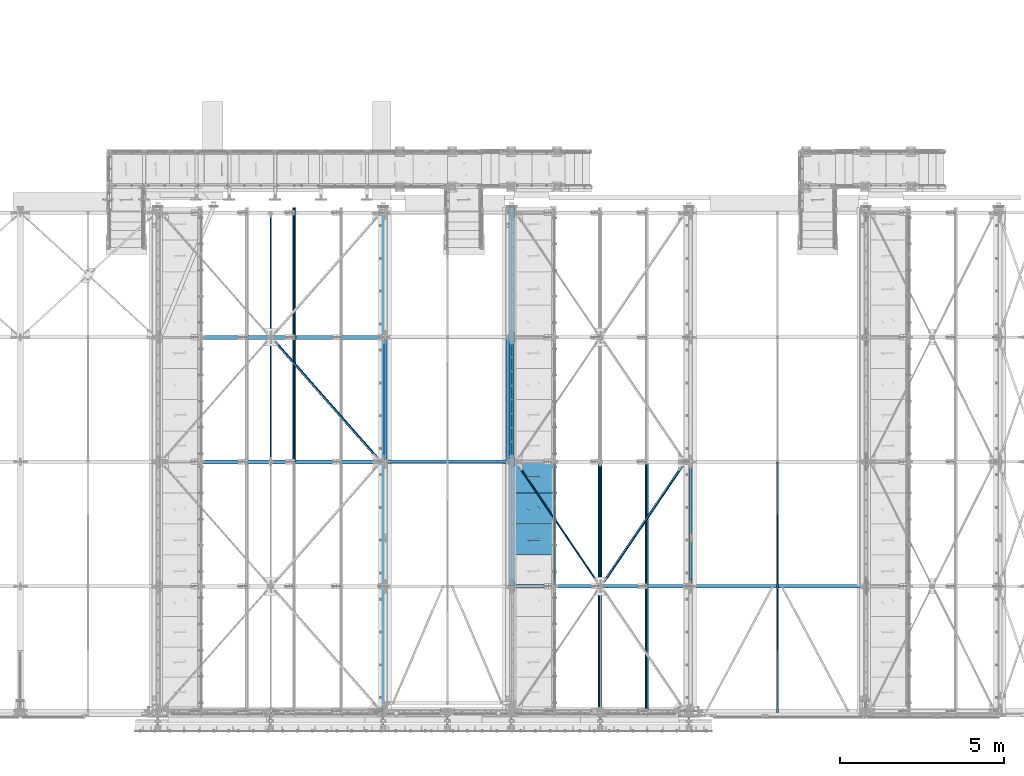
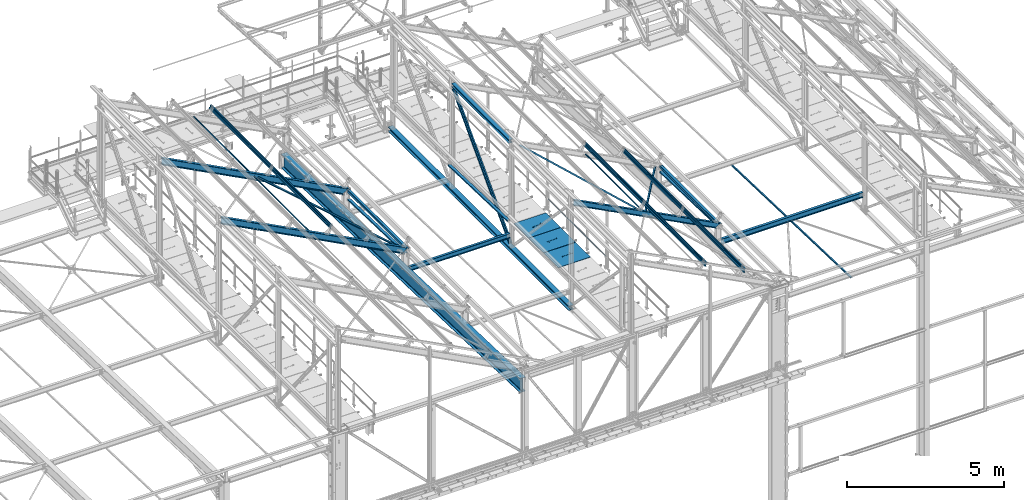
# One storey, part 49 of 496: 24 beams, 5 members, 29 elements without a shape of their own.
"""IFC2X3 building model written with IfcOpenShell, lengths in millimetres."""

from ifc_helpers import new_model, si_unit, frame, origin_with_axes, origin_2d_with_axis, place, context, subcontext, project, spatial, polyline, hollow_rectangle, hollow_circle, i_section, l_section, u_section, outline, extrude, boolean, clip, halfspace, material, type_object, element, aggregate, save


model = new_model("IFC2X3")

# Units and contexts
model_context = context("Model", 3, precision=1e-05, world=origin_with_axes())
body_context = subcontext(model_context, "Body", "Model", "MODEL_VIEW")
ifc_project = project(units=[si_unit("LENGTHUNIT", "METRE", prefix="MILLI"), si_unit("AREAUNIT", "SQUARE_METRE"), si_unit("VOLUMEUNIT", "CUBIC_METRE"), si_unit("MASSUNIT", "GRAM", prefix="KILO"), si_unit("TIMEUNIT", "SECOND"), si_unit("PLANEANGLEUNIT", "RADIAN"), si_unit("SOLIDANGLEUNIT", "STERADIAN"), si_unit("THERMODYNAMICTEMPERATUREUNIT", "DEGREE_CELSIUS"), si_unit("LUMINOUSINTENSITYUNIT", "LUMEN")], contexts=[model_context])

# Site, building, storey
site_placement = place(None, origin_with_axes())
site = spatial("IfcSite", under=ifc_project, at=site_placement, CompositionType="ELEMENT")
building_placement = place(site_placement, origin_with_axes())
building = spatial("IfcBuilding", under=site, at=building_placement, Name="Undefined", CompositionType="ELEMENT")
storey_placement = place(building_placement, origin_with_axes())
storey = spatial("IfcBuildingStorey", under=building, at=storey_placement, Name="Undefined", CompositionType="ELEMENT", Elevation=0.0)

# Assembly, beam
assembly_1_placement = place(storey_placement, origin_with_axes())
assembly_1 = element("IfcElementAssembly", 1, at=assembly_1_placement, inside=storey, AssemblyPlace="NOTDEFINED", PredefinedType="NOTDEFINED")
ifc_material_1 = material(Name="Undefined/S235-E24")
beam_type_1 = type_object("IfcBeamType", PredefinedType="NOTDEFINED")
beam_1_placement = place(assembly_1_placement, frame((31577.0000126668, -53.9015129840809, 7826.58977123183), z_axis=(1.0, 0.0, 0.0), x_axis=(0.0, 0.999506556345274, -0.0314108870109058)))
beam_1 = element("IfcBeam", 2, at=beam_1_placement, type_object=beam_type_1, material=ifc_material_1, context=body_context, shape_type="SweptSolid", body=[
    extrude(l_section(Depth=50.0, Width=50.0, Thickness=5.0, FilletRadius=7.0, EdgeRadius=3.5, at=origin_2d_with_axis()), frame((7648.75199419146, 0.0, 0.0), z_axis=(-1.0, 0.0, 0.0), x_axis=(0.0, -1.0, 0.0)), (0.0, 0.0, 1.0), 7648.75),
])
aggregate(assembly_1, [beam_1])

assembly_2_placement = place(storey_placement, origin_with_axes())
assembly_2 = element("IfcElementAssembly", 3, at=assembly_2_placement, inside=storey, AssemblyPlace="NOTDEFINED", PredefinedType="NOTDEFINED")
beam_type_2 = type_object("IfcBeamType", PredefinedType="NOTDEFINED")
beam_2_placement = place(assembly_2_placement, frame((26186.6844467187, 3798.18132236939, 9918.65169565615), z_axis=(0.460093364927087, 0.0, 0.887870539859315), x_axis=(-0.538249840883414, 0.79529277182776, 0.278920267939601)))
beam_2 = element("IfcBeam", 4, at=beam_2_placement, type_object=beam_type_2, material=ifc_material_1, context=body_context, shape_type="Clipping", body=[
    clip(clip(extrude(l_section(Depth=60.0, Width=60.0, Thickness=6.0, FilletRadius=8.0, EdgeRadius=4.0, at=origin_2d_with_axis()), frame((4700.97244646979, 6.52390981024901e-13, -1.3047819620498e-13), z_axis=(-1.0, 0.0, 0.0), x_axis=(0.0, -1.0, 0.0)), (0.0, 0.0, 1.0), 4623.83), halfspace(frame((4626.03065655955, -30.0002032061129, -29.9999715882914), z_axis=(-1.0, 0.0, 0.0), x_axis=(0.0, 1.0, 0.0)), True)), halfspace(frame((152.084056841757, 30.000000564025, -29.9999483203865), z_axis=(-1.0, 0.0, 0.0), x_axis=(0.0, 0.0, 1.0)), False)),
])
aggregate(assembly_2, [beam_2])

assembly_3_placement = place(storey_placement, origin_with_axes())
assembly_3 = element("IfcElementAssembly", 5, at=assembly_3_placement, inside=storey, AssemblyPlace="NOTDEFINED", PredefinedType="NOTDEFINED")
beam_3_placement = place(assembly_3_placement, frame((16130.7913096929, 11402.1147636975, 10299.8650296818), z_axis=(0.46352885499701, 6.99999093634976e-09, 0.886081824994261), x_axis=(0.624617904868394, -0.709285746850553, -0.32675097893116)))
beam_3 = element("IfcBeam", 6, at=beam_3_placement, type_object=beam_type_2, material=ifc_material_1, context=body_context, shape_type="Clipping", body=[
    clip(clip(extrude(l_section(Depth=60.0, Width=60.0, Thickness=6.0, FilletRadius=8.0, EdgeRadius=4.0, at=origin_2d_with_axis()), frame((5278.55455476531, 2.93018640172022e-13, 0.0), z_axis=(-1.0, 0.0, 0.0), x_axis=(0.0, -1.0, 0.0)), (0.0, 0.0, 1.0), 5199.61), halfspace(frame((5188.72397787064, -29.9999986552884, -29.9999739343803), z_axis=(1.0, 0.0, 0.0), x_axis=(0.0, 0.0, 1.0)), False)), halfspace(frame((168.778056400542, 30.0000013799818, -30.0000003417335), z_axis=(-1.0, 0.0, 0.0), x_axis=(0.0, 0.0, 1.0)), False)),
])
aggregate(assembly_3, [beam_3])

assembly_4_placement = place(storey_placement, origin_with_axes())
assembly_4 = element("IfcElementAssembly", 7, at=assembly_4_placement, inside=storey, AssemblyPlace="NOTDEFINED", PredefinedType="NOTDEFINED")
beam_4_placement = place(assembly_4_placement, frame((28762.7405584196, 7598.18132342838, 8583.74320778802), z_axis=(0.460093364927087, 0.0, 0.887870539859315), x_axis=(-0.538249844036752, -0.795292764054313, 0.27892028401904)))
beam_4 = element("IfcBeam", 8, at=beam_4_placement, type_object=beam_type_2, material=ifc_material_1, context=body_context, shape_type="Clipping", body=[
    clip(clip(extrude(l_section(Depth=60.0, Width=60.0, Thickness=6.0, FilletRadius=8.0, EdgeRadius=4.0, at=origin_2d_with_axis()), frame((4708.9125672795, 1.68829082471735e-12, 0.0), z_axis=(-1.0, 0.0, 0.0), x_axis=(0.0, -1.0, 0.0)), (0.0, 0.0, 1.0), 4639.72), halfspace(frame((4626.03053180101, 30.0000051897205, -29.9999470599651), z_axis=(-1.0, 0.0, 0.0), x_axis=(0.0, 0.0, 1.0)), True)), halfspace(frame((152.077978901132, -29.992502807514, -29.9999728867879), z_axis=(1.0, 0.0, 0.0), x_axis=(0.0, 0.0, 1.0)), True)),
])
aggregate(assembly_4, [beam_4])

assembly_5_placement = place(storey_placement, origin_with_axes())
assembly_5 = element("IfcElementAssembly", 9, at=assembly_5_placement, inside=storey, Name="LISSE", AssemblyPlace="NOTDEFINED", PredefinedType="NOTDEFINED")
beam_type_3 = type_object("IfcBeamType", PredefinedType="NOTDEFINED")
beam_5_placement = place(assembly_5_placement, frame((23353.5001162871, 7602.95853913206, 8291.3293909634), z_axis=(1.0, 0.0, 0.0), x_axis=(0.0, 0.999506445341009, -0.0314144190107172)))
beam_5 = element("IfcBeam", 10, at=beam_5_placement, type_object=beam_type_3, material=ifc_material_1, Name="LISSE", context=body_context, shape_type="SweptSolid", body=[
    extrude(u_section(Depth=100.0, FlangeWidth=50.0, WebThickness=4.0, FlangeThickness=4.0, at=origin_2d_with_axis()), frame((3791.87643071007, 0.0, 0.0), z_axis=(-1.0, 0.0, 0.0), x_axis=(0.0, -1.0, 0.0)), (0.0, 0.0, 1.0), 3791.88),
])
aggregate(assembly_5, [beam_5])

assembly_6_placement = place(storey_placement, origin_with_axes())
assembly_6 = element("IfcElementAssembly", 11, at=assembly_6_placement, inside=storey, Name="LISSE", AssemblyPlace="NOTDEFINED", PredefinedType="NOTDEFINED")
beam_6_placement = place(assembly_6_placement, frame((28930.0000000007, 3800.0, 8410.85601504986), z_axis=(1.0, 0.0, 0.0), x_axis=(0.0, 0.999506445341009, -0.0314144190107172)))
beam_6 = element("IfcBeam", 12, at=beam_6_placement, type_object=beam_type_3, material=ifc_material_1, Name="LISSE", context=body_context, shape_type="Clipping", body=[
    clip(clip(extrude(u_section(Depth=100.0, FlangeWidth=50.0, WebThickness=4.0, FlangeThickness=4.0, at=origin_2d_with_axis()), frame((3748.43648207257, 2.60100030546368e-14, 0.0), z_axis=(-1.0, 0.0, 0.0), x_axis=(0.0, -1.0, 0.0)), (0.0, 0.0, 1.0), 3546.42), halfspace(frame((3745.8562722041, 31.5941023942269, 54.9999999992542), z_axis=(-0.999506472307554, -0.0314135610096736, 0.0), x_axis=(0.0, 0.0, 1.0)), True)), halfspace(frame((202.484021196273, 35.5224298009161, 54.9999999992542), z_axis=(-0.999506472307554, -0.0314135610096736, 0.0), x_axis=(0.0, 0.0, 1.0)), False)),
])
aggregate(assembly_6, [beam_6])

assembly_7_placement = place(storey_placement, origin_with_axes())
assembly_7 = element("IfcElementAssembly", 13, at=assembly_7_placement, inside=storey, Name="LISSE", AssemblyPlace="NOTDEFINED", PredefinedType="NOTDEFINED")
beam_7_placement = place(assembly_7_placement, frame((19620.0000000087, 7600.0, 8291.42237510326), z_axis=(1.0, 0.0, 0.0), x_axis=(0.0, 0.999506445341009, -0.0314144190107172)))
beam_7 = element("IfcBeam", 14, at=beam_7_placement, type_object=beam_type_3, material=ifc_material_1, Name="LISSE", context=body_context, shape_type="Clipping", body=[
    clip(clip(extrude(u_section(Depth=100.0, FlangeWidth=50.0, WebThickness=4.0, FlangeThickness=4.0, at=origin_2d_with_axis()), frame((3738.43154409699, 2.59405798515091e-14, 0.0), z_axis=(-1.0, 0.0, 0.0), x_axis=(0.0, -1.0, 0.0)), (0.0, 0.0, 1.0), 3674.99), halfspace(frame((3731.98221168591, 154.697322046104, 49.9999999913198), z_axis=(-0.999506472307554, -0.0314135610096736, 0.0), x_axis=(0.0, 0.0, 1.0)), True)), halfspace(frame((63.7935542847008, 39.4064997178375, 49.9999999913198), z_axis=(-0.999506472307554, -0.0314135610096736, 0.0), x_axis=(0.0, 0.0, 1.0)), False)),
])
aggregate(assembly_7, [beam_7])

assembly_8_placement = place(storey_placement, origin_with_axes())
assembly_8 = element("IfcElementAssembly", 15, at=assembly_8_placement, inside=storey, Name="LISSE", AssemblyPlace="NOTDEFINED", PredefinedType="NOTDEFINED")
beam_type_4 = type_object("IfcBeamType", PredefinedType="NOTDEFINED")
beam_8_placement = place(assembly_8_placement, frame((28929.9999999877, 3870.0, 8500.0), z_axis=(0.0, 0.0, 1.0), x_axis=(0.0, 1.0, 0.0)))
beam_8 = element("IfcBeam", 16, at=beam_8_placement, type_object=beam_type_4, material=ifc_material_1, Name="LISSE", context=body_context, shape_type="SweptSolid", body=[
    extrude(hollow_rectangle(XDim=100.0, YDim=100.0, WallThickness=4.0, InnerFilletRadius=4.0, OuterFilletRadius=8.0, at=origin_2d_with_axis()), frame((3660.0, 0.0, 0.0), z_axis=(-1.0, 0.0, 0.0), x_axis=(0.0, -1.0, 0.0)), (0.0, 0.0, 1.0), 3660.0),
])
aggregate(assembly_8, [beam_8])

assembly_9_placement = place(storey_placement, origin_with_axes())
assembly_9 = element("IfcElementAssembly", 17, at=assembly_9_placement, inside=storey, Name="LISSE", AssemblyPlace="NOTDEFINED", PredefinedType="NOTDEFINED")
beam_9_placement = place(assembly_9_placement, frame((19619.9999999823, 7670.0, 8500.0), z_axis=(0.0, 0.0, 1.0), x_axis=(0.0, 1.0, 0.0)))
beam_9 = element("IfcBeam", 18, at=beam_9_placement, type_object=beam_type_4, material=ifc_material_1, Name="LISSE", context=body_context, shape_type="SweptSolid", body=[
    extrude(hollow_rectangle(XDim=100.0, YDim=100.0, WallThickness=4.0, InnerFilletRadius=4.0, OuterFilletRadius=8.0, at=origin_2d_with_axis()), frame((3660.0, 0.0, 0.0), z_axis=(-1.0, 0.0, 0.0), x_axis=(0.0, -1.0, 0.0)), (0.0, 0.0, 1.0), 3660.0),
])
aggregate(assembly_9, [beam_9])

assembly_10_placement = place(storey_placement, origin_with_axes())
assembly_10 = element("IfcElementAssembly", 19, at=assembly_10_placement, inside=storey, AssemblyPlace="NOTDEFINED", PredefinedType="NOTDEFINED")
beam_type_5 = type_object("IfcBeamType", PredefinedType="NOTDEFINED")
beam_10_placement = place(assembly_10_placement, frame((24726.4915991611, 5695.00015707402, 8115.0), z_axis=(0.0, 0.0, 1.0), x_axis=(-1.0, 0.0, 0.0)))
beam_10 = element("IfcBeam", 20, at=beam_10_placement, type_object=beam_type_5, material=ifc_material_1, context=body_context, shape_type="CSG", body=[
    boolean("DIFFERENCE", extrude(outline(polyline([(0.0, 0.0), (1179.99169921875, 0.0), (1179.99169921875, 940.0), (-9.39995516091585e-07, 940.0), (0.0, 0.0)])), frame((0.0, 0.0, -15.0), z_axis=(0.0, 0.0, 1.0), x_axis=(1.0, 0.0, 0.0)), (0.0, 0.0, 1.0), 30.0), extrude(outline(polyline([(0.0, 0.0), (9.99999999997453, 6.91215973347425e-11), (10.0000000004329, 75.8578643791443), (282.842712400121, -196.984848017997), (282.842712400743, -96.9848480190813), (272.842712400776, -96.9848480191613), (272.842712400299, -172.842712398218), (0.0, 100.0), (0.0, 0.0)])), frame((724.286946489367, 535.710676888644, -17.5), z_axis=(0.0, 0.0, 1.0), x_axis=(-0.707106781186457, -0.707106781186639, 0.0)), (0.0, 0.0, 1.0), 35.0)),
])
aggregate(assembly_10, [beam_10])

assembly_11_placement = place(storey_placement, origin_with_axes())
assembly_11 = element("IfcElementAssembly", 21, at=assembly_11_placement, inside=storey, AssemblyPlace="NOTDEFINED", PredefinedType="NOTDEFINED")
beam_11_placement = place(assembly_11_placement, frame((24726.4916048611, 6645.00015707402, 8115.0), z_axis=(0.0, 0.0, 1.0), x_axis=(-1.0, 0.0, 0.0)))
beam_11 = element("IfcBeam", 22, at=beam_11_placement, type_object=beam_type_5, material=ifc_material_1, context=body_context, shape_type="CSG", body=[
    boolean("DIFFERENCE", extrude(outline(polyline([(0.0, 0.0), (1179.99169921875, 0.0), (1179.99169921875, 940.0), (-9.39995516091585e-07, 940.0), (0.0, 0.0)])), frame((0.0, 0.0, -15.0), z_axis=(0.0, 0.0, 1.0), x_axis=(1.0, 0.0, 0.0)), (0.0, 0.0, 1.0), 30.0), extrude(outline(polyline([(0.0, 0.0), (9.99999999997453, 6.91215973347425e-11), (10.0000000004329, 75.8578643791443), (282.842712400121, -196.984848017997), (282.842712400743, -96.9848480190813), (272.842712400776, -96.9848480191613), (272.842712400299, -172.842712398218), (0.0, 100.0), (0.0, 0.0)])), frame((724.286946489367, 535.710676888644, -17.5), z_axis=(0.0, 0.0, 1.0), x_axis=(-0.707106781186457, -0.707106781186639, 0.0)), (0.0, 0.0, 1.0), 35.0)),
])
aggregate(assembly_11, [beam_11])

assembly_12_placement = place(storey_placement, origin_with_axes())
assembly_12 = element("IfcElementAssembly", 23, at=assembly_12_placement, inside=storey, AssemblyPlace="NOTDEFINED", PredefinedType="NOTDEFINED")
beam_12_placement = place(assembly_12_placement, frame((24726.4916105611, 7595.00016184328, 8115.0), z_axis=(0.0, 0.0, 1.0), x_axis=(-1.0, 0.0, 0.0)))
beam_12 = element("IfcBeam", 24, at=beam_12_placement, type_object=beam_type_5, material=ifc_material_1, context=body_context, shape_type="CSG", body=[
    boolean("DIFFERENCE", extrude(outline(polyline([(0.0, 0.0), (1179.99169921875, 0.0), (1179.99169921875, 940.0), (-9.39995516091585e-07, 940.0), (0.0, 0.0)])), frame((0.0, 0.0, -15.0), z_axis=(0.0, 0.0, 1.0), x_axis=(1.0, 0.0, 0.0)), (0.0, 0.0, 1.0), 30.0), extrude(outline(polyline([(0.0, 0.0), (9.99999999997453, 6.91215973347425e-11), (10.0000000004329, 75.8578643791443), (282.842712400121, -196.984848017997), (282.842712400743, -96.9848480190813), (272.842712400776, -96.9848480191613), (272.842712400299, -172.842712398218), (0.0, 100.0), (0.0, 0.0)])), frame((724.286946489367, 535.710676888644, -17.5), z_axis=(0.0, 0.0, 1.0), x_axis=(-0.707106781186457, -0.707106781186639, 0.0)), (0.0, 0.0, 1.0), 35.0)),
])
aggregate(assembly_12, [beam_12])

assembly_13_placement = place(storey_placement, origin_with_axes())
assembly_13 = element("IfcElementAssembly", 25, at=assembly_13_placement, inside=storey, Name="MAIN COURANTE", AssemblyPlace="NOTDEFINED", PredefinedType="NOTDEFINED")
beam_type_6 = type_object("IfcBeamType", PredefinedType="NOTDEFINED")
beam_13_placement = place(assembly_13_placement, frame((24783.9916033589, 7545.00000183825, 8673.80000207829), z_axis=(0.0, 0.0, 1.0), x_axis=(0.0, -1.0, 0.0)))
beam_13 = element("IfcBeam", 26, at=beam_13_placement, type_object=beam_type_6, material=ifc_material_1, Name="LISSE", context=body_context, shape_type="SweptSolid", body=[
    extrude(hollow_circle(Radius=13.44999981, WallThickness=2.0, at=origin_2d_with_axis()), frame((3690.00000000169, 3.69000323827281e-24, 0.0), z_axis=(-1.0, 0.0, 0.0), x_axis=(0.0, -1.0, 0.0)), (0.0, 0.0, 1.0), 3690.0),
])
aggregate(assembly_13, [beam_13])

assembly_14_placement = place(storey_placement, origin_with_axes())
assembly_14 = element("IfcElementAssembly", 27, at=assembly_14_placement, inside=storey, AssemblyPlace="NOTDEFINED", PredefinedType="NOTDEFINED")
beam_type_7 = type_object("IfcBeamType", PredefinedType="NOTDEFINED")
beam_14_placement = place(assembly_14_placement, frame((26184.2061471111, 7580.00015091687, 9908.67304438101), z_axis=(-0.887870604061621, -1.29999898490562e-08, 0.460093241031915), x_axis=(-8.13000000285402e-07, -0.999999999999581, 4.20999999948846e-07)))
beam_14 = element("IfcBeam", 28, at=beam_14_placement, type_object=beam_type_7, material=ifc_material_1, context=body_context, shape_type="SweptSolid", body=[
    extrude(hollow_rectangle(XDim=40.0, YDim=40.0, WallThickness=4.0, InnerFilletRadius=4.0, OuterFilletRadius=8.0, at=origin_2d_with_axis()), frame((3700.00150276796, -3.63797900296816e-12, -3.9175289721686e-19), z_axis=(-1.0, 0.0, 0.0), x_axis=(0.0, -1.0, 0.0)), (0.0, 0.0, 1.0), 3700.0),
])
aggregate(assembly_14, [beam_14])

assembly_15_placement = place(storey_placement, origin_with_axes())
assembly_15 = element("IfcElementAssembly", 29, at=assembly_15_placement, inside=storey, AssemblyPlace="NOTDEFINED", PredefinedType="NOTDEFINED")
beam_15_placement = place(assembly_15_placement, frame((16124.270567047, 11320.0015957774, 10291.9905320312), z_axis=(-0.886082013248113, 9.38091927309869e-07, 0.463528495129794), x_axis=(0.0, -1.0, 0.0)))
beam_15 = element("IfcBeam", 30, at=beam_15_placement, type_object=beam_type_7, material=ifc_material_1, context=body_context, shape_type="SweptSolid", body=[
    extrude(hollow_rectangle(XDim=40.0, YDim=40.0, WallThickness=4.0, InnerFilletRadius=4.0, OuterFilletRadius=8.0, at=origin_2d_with_axis()), frame((3700.00159576542, -3.63797880709171e-12, -3.63797880709171e-12), z_axis=(-1.0, 0.0, 0.0), x_axis=(0.0, -1.0, 0.0)), (0.0, 0.0, 1.0), 3700.0),
])
aggregate(assembly_15, [beam_15])

assembly_16_placement = place(storey_placement, origin_with_axes())
assembly_16 = element("IfcElementAssembly", 31, at=assembly_16_placement, inside=storey, AssemblyPlace="NOTDEFINED", PredefinedType="NOTDEFINED")
beam_16_placement = place(assembly_16_placement, frame((16124.2705701058, 15180.000000012, 10291.9905299656), z_axis=(-0.886082013248113, 9.38091927309869e-07, 0.463528495129794), x_axis=(-8.13000000285402e-07, -0.999999999999581, 4.20999999948846e-07)))
beam_16 = element("IfcBeam", 32, at=beam_16_placement, type_object=beam_type_7, material=ifc_material_1, context=body_context, shape_type="SweptSolid", body=[
    extrude(hollow_rectangle(XDim=40.0, YDim=40.0, WallThickness=4.0, InnerFilletRadius=4.0, OuterFilletRadius=8.0, at=origin_2d_with_axis()), frame((3700.00150276796, -3.63797900296816e-12, -3.9175289721686e-19), z_axis=(-1.0, 0.0, 0.0), x_axis=(0.0, -1.0, 0.0)), (0.0, 0.0, 1.0), 3700.0),
])
aggregate(assembly_16, [beam_16])

assembly_17_placement = place(storey_placement, origin_with_axes())
assembly_17 = element("IfcElementAssembly", 33, at=assembly_17_placement, inside=storey, AssemblyPlace="NOTDEFINED", PredefinedType="NOTDEFINED")
ifc_material_2 = material(Name="Undefined/S275-E28")
beam_type_8 = type_object("IfcBeamType", Name="HEA140", PredefinedType="NOTDEFINED")
beam_17_placement = place(assembly_17_placement, frame((23473.5, 11325.0, 11302.5), z_axis=(0.0, 0.0, 1.0), x_axis=(0.0, -1.0, 0.0)))
beam_17 = element("IfcBeam", 34, at=beam_17_placement, type_object=beam_type_8, material=ifc_material_2, ObjectType="HEA140", context=body_context, shape_type="SweptSolid", body=[
    extrude(i_section(OverallWidth=140.0, OverallDepth=133.0, WebThickness=5.5, FlangeThickness=8.5, FilletRadius=12.0, at=origin_2d_with_axis()), frame((3650.0, 0.0, 0.0), z_axis=(-1.0, 0.0, 0.0), x_axis=(0.0, -1.0, 0.0)), (0.0, 0.0, 1.0), 3650.0),
])
aggregate(assembly_17, [beam_17])

assembly_18_placement = place(storey_placement, origin_with_axes())
assembly_18 = element("IfcElementAssembly", 35, at=assembly_18_placement, inside=storey, AssemblyPlace="NOTDEFINED", PredefinedType="NOTDEFINED")
beam_type_9 = type_object("IfcBeamType", Name="HEA180", PredefinedType="NOTDEFINED")
beam_18_placement = place(assembly_18_placement, frame((23470.0, 15350.0000000002, 7164.50000000037), z_axis=(0.0, 0.0, 1.0), x_axis=(0.0, -1.0, 0.0)))
beam_18 = element("IfcBeam", 36, at=beam_18_placement, type_object=beam_type_9, material=ifc_material_2, ObjectType="HEA180", context=body_context, shape_type="SweptSolid", body=[
    extrude(i_section(OverallWidth=180.0, OverallDepth=171.0, WebThickness=6.0, FlangeThickness=9.5, FilletRadius=15.0, at=origin_2d_with_axis()), frame((11545.0000000265, 0.0, 0.0), z_axis=(-1.0, 0.0, 0.0), x_axis=(0.0, -1.0, 0.0)), (0.0, 0.0, 1.0), 11545.0),
])
aggregate(assembly_18, [beam_18])

assembly_19_placement = place(storey_placement, origin_with_axes())
assembly_19 = element("IfcElementAssembly", 37, at=assembly_19_placement, inside=storey, Name="SHED", AssemblyPlace="NOTDEFINED", PredefinedType="NOTDEFINED")
beam_type_10 = type_object("IfcBeamType", PredefinedType="NOTDEFINED")
beam_19_placement = place(assembly_19_placement, frame((27591.6811463629, -154.999920381521, 9562.26025581948), z_axis=(0.460093364927087, 0.0, 0.887870539859315), x_axis=(0.0, 1.0, 0.0)))
beam_19 = element("IfcBeam", 38, at=beam_19_placement, type_object=beam_type_10, material=ifc_material_1, Name="SHED", context=body_context, shape_type="SweptSolid", body=[
    extrude(outline(polyline([(-27.9999999860338, 36.0000000101354), (-27.999999986052, 70.0000000101354), (28.0000000138389, 70.0000000101209), (28.0000000138425, 58.0000000101209), (26.5000000138534, 58.0000000101209), (26.5000000138352, 68.5000000101172), (-26.4999999860593, 68.5000000101354), (-26.4999999860338, 36.7000007730749), (-1.49999998607018, 15.6999998194005), (-1.49999998605563, -15.6999997991297), (-26.4999999859974, -36.7000007527895), (-26.4999999859829, -68.49999998985), (26.5000000139153, -68.4999999898646), (26.500000013908, -57.9999999898646), (28.0000000139116, -57.9999999898646), (28.0000000139153, -69.9999999898646), (-27.9999999859756, -69.99999998985), (-27.9999999859901, -35.99999998985), (-2.99999998605927, -14.9999999898646), (-2.9999999860629, 15.0000000101354), (-27.9999999860338, 36.0000000101354)])), frame((7750.00000000006, -3.63797880548905e-12, 0.0), z_axis=(-1.0, 0.0, 0.0), x_axis=(0.0, -1.0, 0.0)), (0.0, 0.0, 1.0), 7750.0),
])
aggregate(assembly_19, [beam_19])

assembly_20_placement = place(storey_placement, origin_with_axes())
assembly_20 = element("IfcElementAssembly", 39, at=assembly_20_placement, inside=storey, Name="SHED", AssemblyPlace="NOTDEFINED", PredefinedType="NOTDEFINED")
beam_20_placement = place(assembly_20_placement, frame((26165.0561453475, -154.999920381521, 10301.5352320946), z_axis=(0.460093364927087, 0.0, 0.887870539859315), x_axis=(0.0, 1.0, 0.0)))
beam_20 = element("IfcBeam", 40, at=beam_20_placement, type_object=beam_type_10, material=ifc_material_1, Name="SHED", context=body_context, shape_type="SweptSolid", body=[
    extrude(outline(polyline([(-27.9999999860338, 36.0000000101354), (-27.999999986052, 70.0000000101354), (28.0000000138389, 70.0000000101209), (28.0000000138425, 58.0000000101209), (26.5000000138534, 58.0000000101209), (26.5000000138352, 68.5000000101172), (-26.4999999860593, 68.5000000101354), (-26.4999999860338, 36.7000007730749), (-1.49999998607018, 15.6999998194005), (-1.49999998605563, -15.6999997991297), (-26.4999999859974, -36.7000007527895), (-26.4999999859829, -68.49999998985), (26.5000000139153, -68.4999999898646), (26.500000013908, -57.9999999898646), (28.0000000139116, -57.9999999898646), (28.0000000139153, -69.9999999898646), (-27.9999999859756, -69.99999998985), (-27.9999999859901, -35.99999998985), (-2.99999998605927, -14.9999999898646), (-2.9999999860629, 15.0000000101354), (-27.9999999860338, 36.0000000101354)])), frame((7750.00000000006, -3.63797880548905e-12, 0.0), z_axis=(-1.0, 0.0, 0.0), x_axis=(0.0, -1.0, 0.0)), (0.0, 0.0, 1.0), 7750.0),
])
aggregate(assembly_20, [beam_20])

assembly_21_placement = place(storey_placement, origin_with_axes())
assembly_21 = element("IfcElementAssembly", 41, at=assembly_21_placement, inside=storey, Name="SHED", AssemblyPlace="NOTDEFINED", PredefinedType="NOTDEFINED")
beam_21_placement = place(assembly_21_placement, frame((16833.5855150709, 7605.00007961586, 10327.2156401036), z_axis=(0.46352885499701, 6.99999093634976e-09, 0.886081824994261), x_axis=(0.0, 1.0, 0.0)))
beam_21 = element("IfcBeam", 42, at=beam_21_placement, type_object=beam_type_10, material=ifc_material_1, Name="SHED", context=body_context, shape_type="SweptSolid", body=[
    extrude(outline(polyline([(-27.9999999860338, 36.0000000101354), (-27.999999986052, 70.0000000101354), (28.0000000138389, 70.0000000101209), (28.0000000138425, 58.0000000101209), (26.5000000138534, 58.0000000101209), (26.5000000138352, 68.5000000101172), (-26.4999999860593, 68.5000000101354), (-26.4999999860338, 36.7000007730749), (-1.49999998607018, 15.6999998194005), (-1.49999998605563, -15.6999997991297), (-26.4999999859974, -36.7000007527895), (-26.4999999859829, -68.49999998985), (26.5000000139153, -68.4999999898646), (26.500000013908, -57.9999999898646), (28.0000000139116, -57.9999999898646), (28.0000000139153, -69.9999999898646), (-27.9999999859756, -69.99999998985), (-27.9999999859901, -35.99999998985), (-2.99999998605927, -14.9999999898646), (-2.9999999860629, 15.0000000101354), (-27.9999999860338, 36.0000000101354)])), frame((7750.00000000006, -3.63797880548905e-12, 0.0), z_axis=(-1.0, 0.0, 0.0), x_axis=(0.0, -1.0, 0.0)), (0.0, 0.0, 1.0), 7750.0),
])
aggregate(assembly_21, [beam_21])

# Assembly, member
assembly_22_placement = place(storey_placement, origin_with_axes())
assembly_22 = element("IfcElementAssembly", 43, at=assembly_22_placement, inside=storey, AssemblyPlace="NOTDEFINED", PredefinedType="NOTDEFINED")
member_type_1 = type_object("IfcMemberType", Name="UPN80", PredefinedType="NOTDEFINED")
member_1_placement = place(assembly_22_placement, frame((23497.4999999937, 7599.99999999989, 7250.0), z_axis=(0.0, -0.723792360031621, 0.690017840030138), x_axis=(0.0, 0.690017837983532, 0.723792361982726)))
member_1 = element("IfcMember", 44, at=member_1_placement, type_object=member_type_1, material=ifc_material_2, ObjectType="UPN80", context=body_context, shape_type="Clipping", body=[
    clip(clip(extrude(u_section(Depth=80.0, FlangeWidth=45.0, WebThickness=6.0, FlangeThickness=8.0, FilletRadius=8.0, EdgeRadius=4.0, FlangeSlope=0.0798299857122373, at=origin_2d_with_axis()), frame((5467.81196900541, 0.0, 0.0), z_axis=(-1.0, 0.0, 0.0), x_axis=(0.0, -1.0, 0.0)), (0.0, 0.0, 1.0), 5428.52), halfspace(frame((5387.10413923787, 27.5000000297259, 39.9999976635263), z_axis=(1.0, 0.0, 0.0), x_axis=(0.0, 1.0, 0.0)), False)), halfspace(frame((119.999999997919, 27.49999999375, -39.9999989691296), z_axis=(-1.0, 0.0, 0.0), x_axis=(0.0, 1.0, 0.0)), False)),
])
aggregate(assembly_22, [member_1])

assembly_23_placement = place(storey_placement, origin_with_axes())
assembly_23 = element("IfcElementAssembly", 45, at=assembly_23_placement, inside=storey, AssemblyPlace="NOTDEFINED", PredefinedType="NOTDEFINED")
member_2_placement = place(assembly_23_placement, frame((23442.5000000274, 11400.0000003543, 11235.9999997217), z_axis=(0.0, -0.723792360031621, 0.690017840030138), x_axis=(0.0, -0.690017840030137, -0.723792360031622)))
member_2 = element("IfcMember", 46, at=member_2_placement, type_object=member_type_1, material=ifc_material_2, ObjectType="UPN80", context=body_context, shape_type="Clipping", body=[
    clip(clip(extrude(u_section(Depth=80.0, FlangeWidth=45.0, WebThickness=6.0, FlangeThickness=8.0, FilletRadius=8.0, EdgeRadius=4.0, FlangeSlope=0.0798299857122373, at=origin_2d_with_axis()), frame((5467.81196900541, 0.0, 0.0), z_axis=(-1.0, 0.0, 0.0), x_axis=(0.0, -1.0, 0.0)), (0.0, 0.0, 1.0), 5428.52), halfspace(frame((5387.10413924701, 27.4999999683605, -40.0000000000014), z_axis=(1.0, 0.0, 0.0), x_axis=(0.0, -1.0, 0.0)), False)), halfspace(frame((119.999999989826, 27.5000000297296, 39.9999985196016), z_axis=(-1.0, 0.0, 0.0), x_axis=(0.0, -1.0, 0.0)), False)),
])
aggregate(assembly_23, [member_2])

assembly_24_placement = place(storey_placement, origin_with_axes())
assembly_24 = element("IfcElementAssembly", 47, at=assembly_24_placement, inside=storey, Name="TRAVERSE SHED", AssemblyPlace="NOTDEFINED", PredefinedType="NOTDEFINED")
member_type_2 = type_object("IfcMemberType", Name="IPE200", PredefinedType="NOTDEFINED")
member_3_placement = place(assembly_24_placement, frame((23493.9906758698, 3799.99999999682, 11280.2129396085), z_axis=(0.460093364927087, 0.0, 0.887870539859315), x_axis=(0.887870604061616, 0.0, -0.460093241031926)))
member_3 = element("IfcMember", 48, at=member_3_placement, type_object=member_type_2, material=ifc_material_2, Name="TRAVERSE SHED", ObjectType="IPE200", context=body_context, shape_type="Clipping", body=[
    clip(clip(extrude(i_section(OverallWidth=100.0, OverallDepth=200.0, WebThickness=5.599999905, FlangeThickness=8.5, FilletRadius=12.0, at=origin_2d_with_axis()), frame((6236.48041099405, -1.81898940354586e-12, 0.0), z_axis=(-1.0, 0.0, 0.0), x_axis=(0.0, -1.0, 0.0)), (0.0, 0.0, 1.0), 6347.61), halfspace(frame((6005.40058860125, 3.18323145620525e-09, -99.9999999999964), z_axis=(0.854427655127558, 0.0, -0.519570382290236), x_axis=(0.0, -1.0, 0.0)), False)), halfspace(frame((5.77115893586233, 3.18409305520223e-09, 102.990606066072), z_axis=(-0.887870604061619, 0.0, -0.46009324103192), x_axis=(0.0, -1.0, 0.0)), False)),
])
aggregate(assembly_24, [member_3])

assembly_25_placement = place(storey_placement, origin_with_axes())
assembly_25 = element("IfcElementAssembly", 49, at=assembly_25_placement, inside=storey, Name="TRAVERSE SHED", AssemblyPlace="NOTDEFINED", PredefinedType="NOTDEFINED")
member_type_3 = type_object("IfcMemberType", Name="IPE240", PredefinedType="NOTDEFINED")
member_4_placement = place(assembly_25_placement, frame((12694.3765846431, 11399.9999999968, 12063.6701562877), z_axis=(0.46352885499701, 6.99999093634976e-09, 0.886081824994261), x_axis=(0.886081856298361, 3.500000375794e-08, -0.463528795156082)))
member_4 = element("IfcMember", 50, at=member_4_placement, type_object=member_type_3, material=ifc_material_2, Name="TRAVERSE SHED", ObjectType="IPE240", context=body_context, shape_type="Clipping", body=[
    clip(clip(extrude(i_section(OverallWidth=120.0, OverallDepth=240.0, WebThickness=6.199999809, FlangeThickness=9.800000191, FilletRadius=15.0, at=origin_2d_with_axis()), frame((7941.81660004671, -4.54747350886464e-13, 4.40859382336107e-13), z_axis=(-1.0, 0.0, 0.0), x_axis=(0.0, -1.0, 0.0)), (0.0, 0.0, 1.0), 8076.52), halfspace(frame((7809.66068490162, -7599.99999999682, 119.999998325799), z_axis=(-0.855432184782403, 0.0, 0.51791483589332), x_axis=(0.0, -1.0, 0.0)), True)), halfspace(frame((5.75953323153499, 3.18157252429281e-09, 123.012934996157), z_axis=(-0.886082031080585, 0.0, -0.463528461042152), x_axis=(0.0, -1.0, 0.0)), False)),
])
aggregate(assembly_25, [member_4])

assembly_26_placement = place(storey_placement, origin_with_axes())
assembly_26 = element("IfcElementAssembly", 51, at=assembly_26_placement, inside=storey, Name="TRAVERSE SHED", AssemblyPlace="NOTDEFINED", PredefinedType="NOTDEFINED")
member_5_placement = place(assembly_26_placement, frame((12694.3765846431, 7599.99999999682, 12063.6701562877), z_axis=(0.46352885499701, 6.99999093634976e-09, 0.886081824994261), x_axis=(0.886081856298361, 3.500000375794e-08, -0.463528795156082)))
member_5 = element("IfcMember", 52, at=member_5_placement, type_object=member_type_3, material=ifc_material_2, Name="TRAVERSE SHED", ObjectType="IPE240", context=body_context, shape_type="Clipping", body=[
    clip(clip(extrude(i_section(OverallWidth=120.0, OverallDepth=240.0, WebThickness=6.199999809, FlangeThickness=9.800000191, FilletRadius=15.0, at=origin_2d_with_axis()), frame((7941.81660004671, -4.54747350886464e-13, 4.40859382336107e-13), z_axis=(-1.0, 0.0, 0.0), x_axis=(0.0, -1.0, 0.0)), (0.0, 0.0, 1.0), 8076.52), halfspace(frame((7809.66068490162, -3799.99999999682, 119.999998325799), z_axis=(-0.855432184782403, 0.0, 0.51791483589332), x_axis=(0.0, -1.0, 0.0)), True)), halfspace(frame((5.75953323153499, 3.18157252429281e-09, 123.012934996157), z_axis=(-0.886082031080585, 0.0, -0.463528461042152), x_axis=(0.0, -1.0, 0.0)), False)),
])
aggregate(assembly_26, [member_5])

# Assembly, beam
assembly_27_placement = place(storey_placement, origin_with_axes())
assembly_27 = element("IfcElementAssembly", 53, at=assembly_27_placement, inside=storey, AssemblyPlace="NOTDEFINED", PredefinedType="NOTDEFINED")
beam_type_11 = type_object("IfcBeamType", Name="IPE200", PredefinedType="NOTDEFINED")
beam_22_placement = place(assembly_27_placement, frame((28989.9999999994, 3799.99999998817, 7830.53220712507), z_axis=(0.0, 0.031410887010906, 0.999506556345274), x_axis=(1.0, 0.0, 0.0)))
beam_22 = element("IfcBeam", 54, at=beam_22_placement, type_object=beam_type_11, material=ifc_material_2, ObjectType="IPE200", context=body_context, shape_type="SweptSolid", body=[
    extrude(i_section(OverallWidth=100.0, OverallDepth=200.0, WebThickness=5.599999905, FlangeThickness=8.5, FilletRadius=12.0, at=origin_2d_with_axis()), frame((5213.49999999568, 0.0, 0.0), z_axis=(-1.0, 0.0, 0.0), x_axis=(0.0, -1.0, 0.0)), (0.0, 0.0, 1.0), 5213.5),
])
aggregate(assembly_27, [beam_22])

assembly_28_placement = place(storey_placement, origin_with_axes())
assembly_28 = element("IfcElementAssembly", 55, at=assembly_28_placement, inside=storey, AssemblyPlace="NOTDEFINED", PredefinedType="NOTDEFINED")
beam_type_12 = type_object("IfcBeamType", Name="IPE180", PredefinedType="NOTDEFINED")
beam_23_placement = place(assembly_28_placement, frame((19659.9999999989, 7599.99999998552, 7721.11590289579), z_axis=(0.0, 0.031410887010906, 0.999506556345274), x_axis=(1.0, 0.0, 0.0)))
beam_23 = element("IfcBeam", 56, at=beam_23_placement, type_object=beam_type_12, material=ifc_material_2, ObjectType="IPE180", context=body_context, shape_type="SweptSolid", body=[
    extrude(i_section(OverallWidth=91.0, OverallDepth=180.0, WebThickness=5.300000191, FlangeThickness=8.0, FilletRadius=9.0, at=origin_2d_with_axis()), frame((3733.49999999622, 0.0, 0.0), z_axis=(-1.0, 0.0, 0.0), x_axis=(0.0, -1.0, 0.0)), (0.0, 0.0, 1.0), 3733.5),
])
aggregate(assembly_28, [beam_23])

assembly_29_placement = place(storey_placement, origin_with_axes())
assembly_29 = element("IfcElementAssembly", 57, at=assembly_29_placement, inside=storey, Name="TRAVERSE", AssemblyPlace="NOTDEFINED", PredefinedType="NOTDEFINED")
beam_type_13 = type_object("IfcBeamType", Name="IPE550", PredefinedType="NOTDEFINED")
beam_24_placement = place(assembly_29_placement, frame((19550.0000000007, -8.63795872800682, 7775.13569589744), z_axis=(0.0, -0.031410887010906, -0.999506556345274), x_axis=(0.0, 0.999506556345274, -0.0314108870109058)))
beam_24 = element("IfcBeam", 58, at=beam_24_placement, type_object=beam_type_13, material=ifc_material_2, Name="TRAVERSE", ObjectType="IPE550", context=body_context, shape_type="Clipping", body=[
    clip(clip(extrude(i_section(OverallWidth=210.0, OverallDepth=550.0, WebThickness=11.10000038, FlangeThickness=17.20000076, FilletRadius=24.0, at=origin_2d_with_axis()), frame((15397.5977849943, 0.0, 0.0), z_axis=(-1.0, 0.0, 0.0), x_axis=(0.0, -1.0, 0.0)), (0.0, 0.0, 1.0), 15397.6), halfspace(frame((110.024691469667, 105.0, -275.942322770346), z_axis=(-0.999506560367824, 0.0, 0.0314107590115593), x_axis=(0.0314107590115582, 0.0, 0.999506560367824)), False)), halfspace(frame((15357.5780376579, -105.0, -275.0), z_axis=(0.999506560367824, 0.0, -0.0314107590115582), x_axis=(0.0314107590115582, 0.0, 0.999506560367824)), False)),
])
aggregate(assembly_29, [beam_24])

save(model, "model.ifc")
